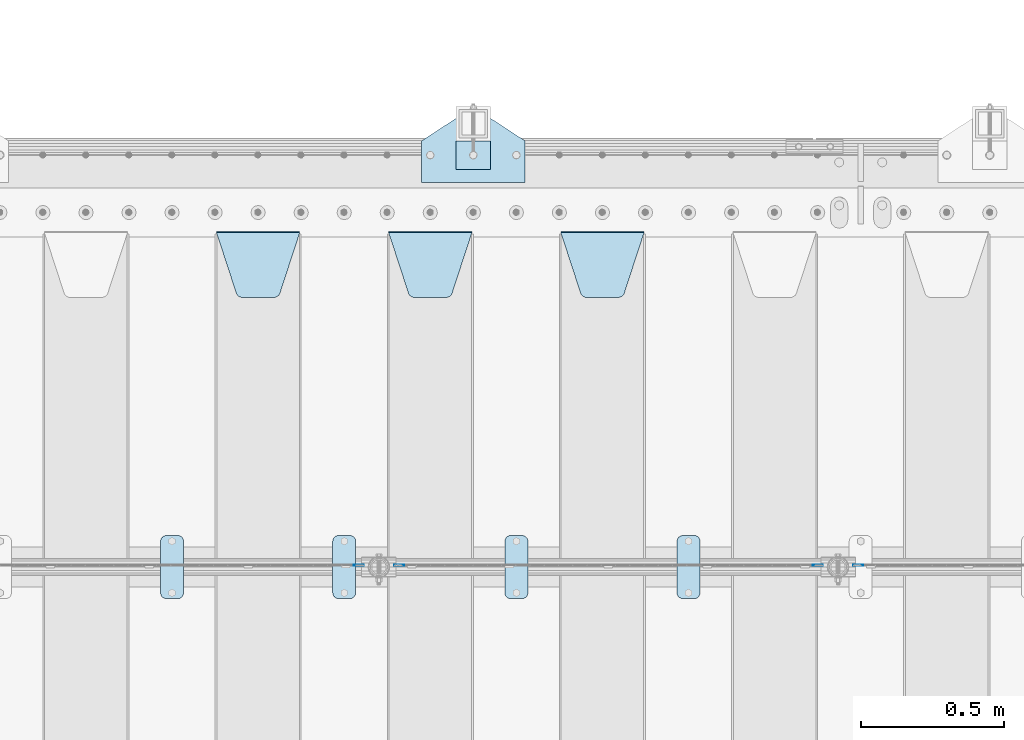
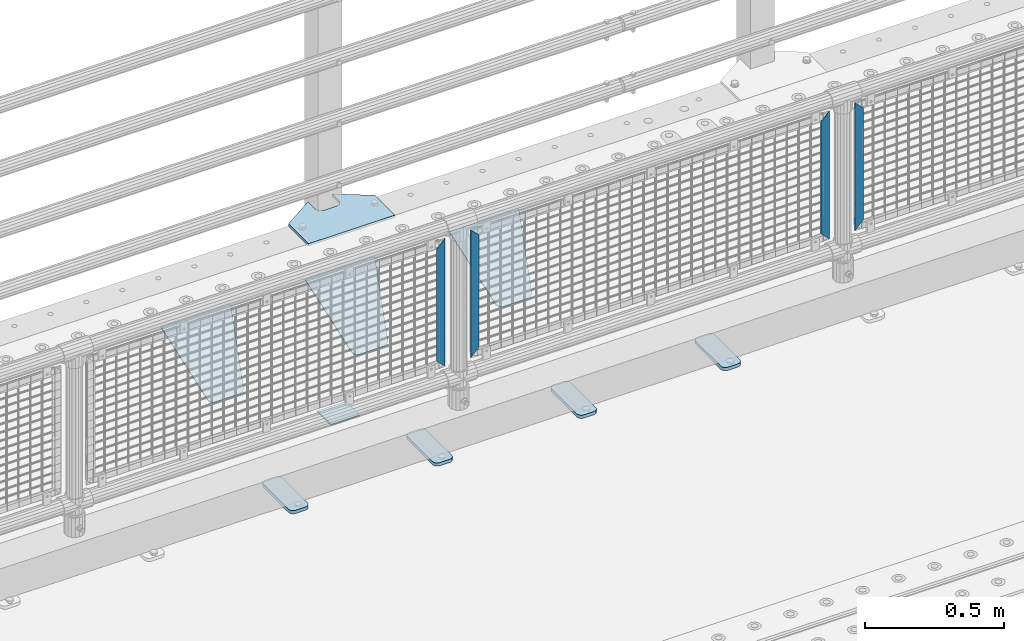
# One storey, part 215 of 247: 13 plates.
"""IFC2X3 building model written with IfcOpenShell, lengths in millimetres."""

from ifc_helpers import new_model, si_unit, frame, origin_with_axes, place, context, subcontext, project, spatial, faceted_brep, material, type_object, element, save


model = new_model("IFC2X3")

# Units and contexts
model_context = context("Model", 3, precision=1e-05, world=origin_with_axes())
body_context = subcontext(model_context, "Body", "Model", "MODEL_VIEW")
ifc_project = project(units=[si_unit("LENGTHUNIT", "METRE", prefix="MILLI"), si_unit("AREAUNIT", "SQUARE_METRE"), si_unit("VOLUMEUNIT", "CUBIC_METRE"), si_unit("MASSUNIT", "GRAM", prefix="KILO"), si_unit("TIMEUNIT", "SECOND"), si_unit("PLANEANGLEUNIT", "RADIAN"), si_unit("SOLIDANGLEUNIT", "STERADIAN"), si_unit("THERMODYNAMICTEMPERATUREUNIT", "DEGREE_CELSIUS"), si_unit("LUMINOUSINTENSITYUNIT", "LUMEN")], contexts=[model_context])

# Site, building, storey
site_placement = place(None, origin_with_axes())
site = spatial("IfcSite", under=ifc_project, at=site_placement, CompositionType="ELEMENT")
building_placement = place(site_placement, origin_with_axes())
building = spatial("IfcBuilding", under=site, at=building_placement, Name="Standard", CompositionType="ELEMENT")
storey_placement = place(building_placement, origin_with_axes())
storey = spatial("IfcBuildingStorey", under=building, at=storey_placement, Name="Undefined", CompositionType="ELEMENT", Elevation=0.0)

# Plates
ifc_material_1 = material(Name="STEEL/S355J2")
plate_type_1 = type_object("IfcPlateType", PredefinedType="NOTDEFINED")
plate_1_placement = place(storey_placement, frame((4860.0, 7774.5, 21.0199999999977), z_axis=(1.0, 0.0, 0.0), x_axis=(0.0, -0.999999999999548, -9.5100000000016e-07)))
element("IfcPlate", 1, at=plate_1_placement, inside=storey, type_object=plate_type_1, material=ifc_material_1, context=body_context, shape_type="Brep", body=[
    faceted_brep([(0.0, -7.0, 20.0), (0.0, -7.0, 60.0), (0.0, 7.0, 60.0), (0.0, 7.0, 20.0), (0.384294391935327, -7.0, 63.9018064403226), (0.384294391935327, 7.0, 63.9018064403226), (1.52240934977453, -7.0, 67.6536686473009), (1.52240934977453, 7.0, 67.6536686473009), (3.37060775394912, -7.0, 71.1114046603925), (3.37060775394912, 7.0, 71.1114046603925), (5.85786437626939, -7.0, 74.1421356237315), (5.85786437626939, 7.0, 74.1421356237315), (8.8885953396084, -7.0, 76.6293922460518), (8.8885953396084, 7.0, 76.6293922460518), (12.3463313526981, -7.0, 78.4775906502255), (12.3463313526981, 7.0, 78.4775906502255), (16.0981935596774, -7.0, 79.6157056080647), (16.0981935596774, 7.0, 79.6157056080647), (20.0, -7.0, 80.0), (20.0, 7.0, 80.0), (200.0, -7.0, 80.0), (200.0, 7.0, 80.0), (203.901806440323, -7.0, 79.6157056080647), (203.901806440323, 7.0, 79.6157056080647), (207.653668647302, -7.0, 78.4775906502255), (207.653668647302, 7.0, 78.4775906502255), (211.111404660392, -7.0, 76.6293922460518), (211.111404660392, 7.0, 76.6293922460518), (214.142135623731, -7.0, 74.1421356237315), (214.142135623731, 7.0, 74.1421356237315), (216.629392246051, -7.0, 71.1114046603925), (216.629392246051, 7.0, 71.1114046603925), (218.477590650225, -7.0, 67.6536686473009), (218.477590650225, 7.0, 67.6536686473009), (219.615705608065, -7.0, 63.9018064403226), (219.615705608065, 7.0, 63.9018064403226), (220.0, -7.0, 60.0), (220.0, 7.0, 60.0), (220.0, -7.0, 20.0), (220.0, 7.0, 20.0), (219.615705608065, -7.0, 16.0981935596774), (219.615705608065, 7.0, 16.0981935596774), (218.477590650225, -7.0, 12.3463313526991), (218.477590650225, 7.0, 12.3463313526991), (216.629392246051, -7.0, 8.88859533960749), (216.629392246051, 7.0, 8.88859533960749), (214.142135623731, -7.0, 5.85786437626848), (214.142135623731, 7.0, 5.85786437626848), (211.111404660392, -7.0, 3.37060775394821), (211.111404660392, 7.0, 3.37060775394821), (207.653668647302, -7.0, 1.52240934977453), (207.653668647302, 7.0, 1.52240934977453), (203.901806440323, -7.0, 0.384294391935327), (203.901806440323, 7.0, 0.384294391935327), (200.0, -7.0, 0.0), (200.0, 7.0, 0.0), (20.0, -7.0, 0.0), (20.0, 7.0, 0.0), (16.0981935596774, -7.0, 0.384294391935327), (16.0981935596774, 7.0, 0.384294391935327), (12.3463313526981, -7.0, 1.52240934977453), (12.3463313526981, 7.0, 1.52240934977453), (8.8885953396084, -7.0, 3.37060775394821), (8.8885953396084, 7.0, 3.37060775394821), (5.85786437626939, -7.0, 5.85786437626848), (5.85786437626939, 7.0, 5.85786437626848), (3.37060775394912, -7.0, 8.88859533960749), (3.37060775394912, 7.0, 8.88859533960749), (1.52240934977453, -7.0, 12.3463313526991), (1.52240934977453, 7.0, 12.3463313526991), (0.384294391935327, -7.0, 16.0981935596774), (0.384294391935327, 7.0, 16.0981935596774)], [[[0, 1, 2, 3]], [[1, 4, 5, 2]], [[4, 6, 7, 5]], [[6, 8, 9, 7]], [[8, 10, 11, 9]], [[10, 12, 13, 11]], [[12, 14, 15, 13]], [[14, 16, 17, 15]], [[16, 18, 19, 17]], [[18, 20, 21, 19]], [[20, 22, 23, 21]], [[22, 24, 25, 23]], [[24, 26, 27, 25]], [[26, 28, 29, 27]], [[28, 30, 31, 29]], [[30, 32, 33, 31]], [[32, 34, 35, 33]], [[34, 36, 37, 35]], [[36, 38, 39, 37]], [[38, 40, 41, 39]], [[40, 42, 43, 41]], [[42, 44, 45, 43]], [[44, 46, 47, 45]], [[46, 48, 49, 47]], [[48, 50, 51, 49]], [[50, 52, 53, 51]], [[52, 54, 55, 53]], [[54, 56, 57, 55]], [[56, 58, 59, 57]], [[58, 60, 61, 59]], [[60, 62, 63, 61]], [[62, 64, 65, 63]], [[64, 66, 67, 65]], [[66, 68, 69, 67]], [[68, 70, 71, 69]], [[70, 0, 3, 71]], [[5, 7, 9, 11, 13, 15, 17, 19, 21, 23, 25, 27, 29, 31, 33, 35, 37, 39, 41, 43, 45, 47, 49, 51, 53, 55, 57, 59, 61, 63, 65, 67, 69, 71, 3, 2]], [[70, 68, 66, 64, 62, 60, 58, 56, 54, 52, 50, 48, 46, 44, 42, 40, 38, 36, 34, 32, 30, 28, 26, 24, 22, 20, 18, 16, 14, 12, 10, 8, 6, 4, 1, 0]]]),
])
plate_2_placement = place(storey_placement, frame((4260.0, 7774.5, 21.0199999999977), z_axis=(1.0, 0.0, 0.0), x_axis=(0.0, -0.999999999999548, -9.5100000000016e-07)))
element("IfcPlate", 2, at=plate_2_placement, inside=storey, type_object=plate_type_1, material=ifc_material_1, context=body_context, shape_type="Brep", body=[
    faceted_brep([(0.0, -7.0, 20.0), (0.0, -7.0, 60.0), (0.0, 7.0, 60.0), (0.0, 7.0, 20.0), (0.384294391935327, -7.0, 63.9018064403226), (0.384294391935327, 7.0, 63.9018064403226), (1.52240934977453, -7.0, 67.6536686473009), (1.52240934977453, 7.0, 67.6536686473009), (3.37060775394912, -7.0, 71.1114046603925), (3.37060775394912, 7.0, 71.1114046603925), (5.85786437626939, -7.0, 74.1421356237315), (5.85786437626939, 7.0, 74.1421356237315), (8.8885953396084, -7.0, 76.6293922460518), (8.8885953396084, 7.0, 76.6293922460518), (12.3463313526981, -7.0, 78.4775906502255), (12.3463313526981, 7.0, 78.4775906502255), (16.0981935596774, -7.0, 79.6157056080647), (16.0981935596774, 7.0, 79.6157056080647), (20.0, -7.0, 80.0), (20.0, 7.0, 80.0), (200.0, -7.0, 80.0), (200.0, 7.0, 80.0), (203.901806440323, -7.0, 79.6157056080647), (203.901806440323, 7.0, 79.6157056080647), (207.653668647302, -7.0, 78.4775906502255), (207.653668647302, 7.0, 78.4775906502255), (211.111404660392, -7.0, 76.6293922460518), (211.111404660392, 7.0, 76.6293922460518), (214.142135623731, -7.0, 74.1421356237315), (214.142135623731, 7.0, 74.1421356237315), (216.629392246051, -7.0, 71.1114046603925), (216.629392246051, 7.0, 71.1114046603925), (218.477590650225, -7.0, 67.6536686473009), (218.477590650225, 7.0, 67.6536686473009), (219.615705608065, -7.0, 63.9018064403226), (219.615705608065, 7.0, 63.9018064403226), (220.0, -7.0, 60.0), (220.0, 7.0, 60.0), (220.0, -7.0, 20.0), (220.0, 7.0, 20.0), (219.615705608065, -7.0, 16.0981935596774), (219.615705608065, 7.0, 16.0981935596774), (218.477590650225, -7.0, 12.3463313526991), (218.477590650225, 7.0, 12.3463313526991), (216.629392246051, -7.0, 8.88859533960749), (216.629392246051, 7.0, 8.88859533960749), (214.142135623731, -7.0, 5.85786437626848), (214.142135623731, 7.0, 5.85786437626848), (211.111404660392, -7.0, 3.37060775394821), (211.111404660392, 7.0, 3.37060775394821), (207.653668647302, -7.0, 1.52240934977453), (207.653668647302, 7.0, 1.52240934977453), (203.901806440323, -7.0, 0.384294391935327), (203.901806440323, 7.0, 0.384294391935327), (200.0, -7.0, 0.0), (200.0, 7.0, 0.0), (20.0, -7.0, 0.0), (20.0, 7.0, 0.0), (16.0981935596774, -7.0, 0.384294391935327), (16.0981935596774, 7.0, 0.384294391935327), (12.3463313526981, -7.0, 1.52240934977453), (12.3463313526981, 7.0, 1.52240934977453), (8.8885953396084, -7.0, 3.37060775394821), (8.8885953396084, 7.0, 3.37060775394821), (5.85786437626939, -7.0, 5.85786437626848), (5.85786437626939, 7.0, 5.85786437626848), (3.37060775394912, -7.0, 8.88859533960749), (3.37060775394912, 7.0, 8.88859533960749), (1.52240934977453, -7.0, 12.3463313526991), (1.52240934977453, 7.0, 12.3463313526991), (0.384294391935327, -7.0, 16.0981935596774), (0.384294391935327, 7.0, 16.0981935596774)], [[[0, 1, 2, 3]], [[1, 4, 5, 2]], [[4, 6, 7, 5]], [[6, 8, 9, 7]], [[8, 10, 11, 9]], [[10, 12, 13, 11]], [[12, 14, 15, 13]], [[14, 16, 17, 15]], [[16, 18, 19, 17]], [[18, 20, 21, 19]], [[20, 22, 23, 21]], [[22, 24, 25, 23]], [[24, 26, 27, 25]], [[26, 28, 29, 27]], [[28, 30, 31, 29]], [[30, 32, 33, 31]], [[32, 34, 35, 33]], [[34, 36, 37, 35]], [[36, 38, 39, 37]], [[38, 40, 41, 39]], [[40, 42, 43, 41]], [[42, 44, 45, 43]], [[44, 46, 47, 45]], [[46, 48, 49, 47]], [[48, 50, 51, 49]], [[50, 52, 53, 51]], [[52, 54, 55, 53]], [[54, 56, 57, 55]], [[56, 58, 59, 57]], [[58, 60, 61, 59]], [[60, 62, 63, 61]], [[62, 64, 65, 63]], [[64, 66, 67, 65]], [[66, 68, 69, 67]], [[68, 70, 71, 69]], [[70, 0, 3, 71]], [[5, 7, 9, 11, 13, 15, 17, 19, 21, 23, 25, 27, 29, 31, 33, 35, 37, 39, 41, 43, 45, 47, 49, 51, 53, 55, 57, 59, 61, 63, 65, 67, 69, 71, 3, 2]], [[70, 68, 66, 64, 62, 60, 58, 56, 54, 52, 50, 48, 46, 44, 42, 40, 38, 36, 34, 32, 30, 28, 26, 24, 22, 20, 18, 16, 14, 12, 10, 8, 6, 4, 1, 0]]]),
])
plate_3_placement = place(storey_placement, frame((3660.0, 7774.5, 21.0199999999977), z_axis=(1.0, 0.0, 0.0), x_axis=(0.0, -0.999999999999548, -9.5100000000016e-07)))
element("IfcPlate", 3, at=plate_3_placement, inside=storey, type_object=plate_type_1, material=ifc_material_1, context=body_context, shape_type="Brep", body=[
    faceted_brep([(0.0, -7.0, 20.0), (0.0, -7.0, 60.0), (0.0, 7.0, 60.0), (0.0, 7.0, 20.0), (0.384294391935327, -7.0, 63.9018064403226), (0.384294391935327, 7.0, 63.9018064403226), (1.52240934977453, -7.0, 67.6536686473009), (1.52240934977453, 7.0, 67.6536686473009), (3.37060775394912, -7.0, 71.1114046603925), (3.37060775394912, 7.0, 71.1114046603925), (5.85786437626939, -7.0, 74.1421356237315), (5.85786437626939, 7.0, 74.1421356237315), (8.8885953396084, -7.0, 76.6293922460518), (8.8885953396084, 7.0, 76.6293922460518), (12.3463313526981, -7.0, 78.4775906502255), (12.3463313526981, 7.0, 78.4775906502255), (16.0981935596774, -7.0, 79.6157056080647), (16.0981935596774, 7.0, 79.6157056080647), (20.0, -7.0, 80.0), (20.0, 7.0, 80.0), (200.0, -7.0, 80.0), (200.0, 7.0, 80.0), (203.901806440323, -7.0, 79.6157056080647), (203.901806440323, 7.0, 79.6157056080647), (207.653668647302, -7.0, 78.4775906502255), (207.653668647302, 7.0, 78.4775906502255), (211.111404660392, -7.0, 76.6293922460518), (211.111404660392, 7.0, 76.6293922460518), (214.142135623731, -7.0, 74.1421356237315), (214.142135623731, 7.0, 74.1421356237315), (216.629392246051, -7.0, 71.1114046603925), (216.629392246051, 7.0, 71.1114046603925), (218.477590650225, -7.0, 67.6536686473009), (218.477590650225, 7.0, 67.6536686473009), (219.615705608065, -7.0, 63.9018064403226), (219.615705608065, 7.0, 63.9018064403226), (220.0, -7.0, 60.0), (220.0, 7.0, 60.0), (220.0, -7.0, 20.0), (220.0, 7.0, 20.0), (219.615705608065, -7.0, 16.0981935596774), (219.615705608065, 7.0, 16.0981935596774), (218.477590650225, -7.0, 12.3463313526991), (218.477590650225, 7.0, 12.3463313526991), (216.629392246051, -7.0, 8.88859533960749), (216.629392246051, 7.0, 8.88859533960749), (214.142135623731, -7.0, 5.85786437626848), (214.142135623731, 7.0, 5.85786437626848), (211.111404660392, -7.0, 3.37060775394821), (211.111404660392, 7.0, 3.37060775394821), (207.653668647302, -7.0, 1.52240934977453), (207.653668647302, 7.0, 1.52240934977453), (203.901806440323, -7.0, 0.384294391935327), (203.901806440323, 7.0, 0.384294391935327), (200.0, -7.0, 0.0), (200.0, 7.0, 0.0), (20.0, -7.0, 0.0), (20.0, 7.0, 0.0), (16.0981935596774, -7.0, 0.384294391935327), (16.0981935596774, 7.0, 0.384294391935327), (12.3463313526981, -7.0, 1.52240934977453), (12.3463313526981, 7.0, 1.52240934977453), (8.8885953396084, -7.0, 3.37060775394821), (8.8885953396084, 7.0, 3.37060775394821), (5.85786437626939, -7.0, 5.85786437626848), (5.85786437626939, 7.0, 5.85786437626848), (3.37060775394912, -7.0, 8.88859533960749), (3.37060775394912, 7.0, 8.88859533960749), (1.52240934977453, -7.0, 12.3463313526991), (1.52240934977453, 7.0, 12.3463313526991), (0.384294391935327, -7.0, 16.0981935596774), (0.384294391935327, 7.0, 16.0981935596774)], [[[0, 1, 2, 3]], [[1, 4, 5, 2]], [[4, 6, 7, 5]], [[6, 8, 9, 7]], [[8, 10, 11, 9]], [[10, 12, 13, 11]], [[12, 14, 15, 13]], [[14, 16, 17, 15]], [[16, 18, 19, 17]], [[18, 20, 21, 19]], [[20, 22, 23, 21]], [[22, 24, 25, 23]], [[24, 26, 27, 25]], [[26, 28, 29, 27]], [[28, 30, 31, 29]], [[30, 32, 33, 31]], [[32, 34, 35, 33]], [[34, 36, 37, 35]], [[36, 38, 39, 37]], [[38, 40, 41, 39]], [[40, 42, 43, 41]], [[42, 44, 45, 43]], [[44, 46, 47, 45]], [[46, 48, 49, 47]], [[48, 50, 51, 49]], [[50, 52, 53, 51]], [[52, 54, 55, 53]], [[54, 56, 57, 55]], [[56, 58, 59, 57]], [[58, 60, 61, 59]], [[60, 62, 63, 61]], [[62, 64, 65, 63]], [[64, 66, 67, 65]], [[66, 68, 69, 67]], [[68, 70, 71, 69]], [[70, 0, 3, 71]], [[5, 7, 9, 11, 13, 15, 17, 19, 21, 23, 25, 27, 29, 31, 33, 35, 37, 39, 41, 43, 45, 47, 49, 51, 53, 55, 57, 59, 61, 63, 65, 67, 69, 71, 3, 2]], [[70, 68, 66, 64, 62, 60, 58, 56, 54, 52, 50, 48, 46, 44, 42, 40, 38, 36, 34, 32, 30, 28, 26, 24, 22, 20, 18, 16, 14, 12, 10, 8, 6, 4, 1, 0]]]),
])
plate_4_placement = place(storey_placement, frame((3060.0, 7774.5, 21.0199999999977), z_axis=(1.0, 0.0, 0.0), x_axis=(0.0, -0.999999999999548, -9.5100000000016e-07)))
element("IfcPlate", 4, at=plate_4_placement, inside=storey, type_object=plate_type_1, material=ifc_material_1, context=body_context, shape_type="Brep", body=[
    faceted_brep([(0.0, -7.0, 20.0), (0.0, -7.0, 60.0), (0.0, 7.0, 60.0), (0.0, 7.0, 20.0), (0.384294391935327, -7.0, 63.9018064403226), (0.384294391935327, 7.0, 63.9018064403226), (1.52240934977453, -7.0, 67.6536686473009), (1.52240934977453, 7.0, 67.6536686473009), (3.37060775394912, -7.0, 71.1114046603925), (3.37060775394912, 7.0, 71.1114046603925), (5.85786437626939, -7.0, 74.1421356237315), (5.85786437626939, 7.0, 74.1421356237315), (8.8885953396084, -7.0, 76.6293922460518), (8.8885953396084, 7.0, 76.6293922460518), (12.3463313526981, -7.0, 78.4775906502255), (12.3463313526981, 7.0, 78.4775906502255), (16.0981935596774, -7.0, 79.6157056080647), (16.0981935596774, 7.0, 79.6157056080647), (20.0, -7.0, 80.0), (20.0, 7.0, 80.0), (200.0, -7.0, 80.0), (200.0, 7.0, 80.0), (203.901806440323, -7.0, 79.6157056080647), (203.901806440323, 7.0, 79.6157056080647), (207.653668647302, -7.0, 78.4775906502255), (207.653668647302, 7.0, 78.4775906502255), (211.111404660392, -7.0, 76.6293922460518), (211.111404660392, 7.0, 76.6293922460518), (214.142135623731, -7.0, 74.1421356237315), (214.142135623731, 7.0, 74.1421356237315), (216.629392246051, -7.0, 71.1114046603925), (216.629392246051, 7.0, 71.1114046603925), (218.477590650225, -7.0, 67.6536686473009), (218.477590650225, 7.0, 67.6536686473009), (219.615705608065, -7.0, 63.9018064403226), (219.615705608065, 7.0, 63.9018064403226), (220.0, -7.0, 60.0), (220.0, 7.0, 60.0), (220.0, -7.0, 20.0), (220.0, 7.0, 20.0), (219.615705608065, -7.0, 16.0981935596774), (219.615705608065, 7.0, 16.0981935596774), (218.477590650225, -7.0, 12.3463313526991), (218.477590650225, 7.0, 12.3463313526991), (216.629392246051, -7.0, 8.88859533960749), (216.629392246051, 7.0, 8.88859533960749), (214.142135623731, -7.0, 5.85786437626848), (214.142135623731, 7.0, 5.85786437626848), (211.111404660392, -7.0, 3.37060775394821), (211.111404660392, 7.0, 3.37060775394821), (207.653668647302, -7.0, 1.52240934977453), (207.653668647302, 7.0, 1.52240934977453), (203.901806440323, -7.0, 0.384294391935327), (203.901806440323, 7.0, 0.384294391935327), (200.0, -7.0, 0.0), (200.0, 7.0, 0.0), (20.0, -7.0, 0.0), (20.0, 7.0, 0.0), (16.0981935596774, -7.0, 0.384294391935327), (16.0981935596774, 7.0, 0.384294391935327), (12.3463313526981, -7.0, 1.52240934977453), (12.3463313526981, 7.0, 1.52240934977453), (8.8885953396084, -7.0, 3.37060775394821), (8.8885953396084, 7.0, 3.37060775394821), (5.85786437626939, -7.0, 5.85786437626848), (5.85786437626939, 7.0, 5.85786437626848), (3.37060775394912, -7.0, 8.88859533960749), (3.37060775394912, 7.0, 8.88859533960749), (1.52240934977453, -7.0, 12.3463313526991), (1.52240934977453, 7.0, 12.3463313526991), (0.384294391935327, -7.0, 16.0981935596774), (0.384294391935327, 7.0, 16.0981935596774)], [[[0, 1, 2, 3]], [[1, 4, 5, 2]], [[4, 6, 7, 5]], [[6, 8, 9, 7]], [[8, 10, 11, 9]], [[10, 12, 13, 11]], [[12, 14, 15, 13]], [[14, 16, 17, 15]], [[16, 18, 19, 17]], [[18, 20, 21, 19]], [[20, 22, 23, 21]], [[22, 24, 25, 23]], [[24, 26, 27, 25]], [[26, 28, 29, 27]], [[28, 30, 31, 29]], [[30, 32, 33, 31]], [[32, 34, 35, 33]], [[34, 36, 37, 35]], [[36, 38, 39, 37]], [[38, 40, 41, 39]], [[40, 42, 43, 41]], [[42, 44, 45, 43]], [[44, 46, 47, 45]], [[46, 48, 49, 47]], [[48, 50, 51, 49]], [[50, 52, 53, 51]], [[52, 54, 55, 53]], [[54, 56, 57, 55]], [[56, 58, 59, 57]], [[58, 60, 61, 59]], [[60, 62, 63, 61]], [[62, 64, 65, 63]], [[64, 66, 67, 65]], [[66, 68, 69, 67]], [[68, 70, 71, 69]], [[70, 0, 3, 71]], [[5, 7, 9, 11, 13, 15, 17, 19, 21, 23, 25, 27, 29, 31, 33, 35, 37, 39, 41, 43, 45, 47, 49, 51, 53, 55, 57, 59, 61, 63, 65, 67, 69, 71, 3, 2]], [[70, 68, 66, 64, 62, 60, 58, 56, 54, 52, 50, 48, 46, 44, 42, 40, 38, 36, 34, 32, 30, 28, 26, 24, 22, 20, 18, 16, 14, 12, 10, 8, 6, 4, 1, 0]]]),
])
ifc_material_2 = material(Name="STEEL/S355N")
plate_type_2 = type_object("IfcPlateType", PredefinedType="NOTDEFINED")
plate_5_placement = place(storey_placement, frame((4455.0, 8831.76776695594, -1.767766952965), z_axis=(0.0, -0.707106781186548, -0.707106781186547), x_axis=(1.0, 0.0, 0.0)))
element("IfcPlate", 5, at=plate_5_placement, inside=storey, type_object=plate_type_2, material=ifc_material_2, context=body_context, shape_type="Brep", body=[
    faceted_brep([(0.0, -2.49999999999909, 0.0), (69.345504679477, -2.5, 300.17173142483), (69.345504679477, 2.50000000000091, 300.171731424831), (0.0, 2.5, -9.09494701772928e-13), (70.9274061199576, -2.5, 304.897442415399), (70.9274061199576, 2.50000000000091, 304.8974424154), (73.3818627772307, -2.49999999999909, 309.234538108527), (73.3818627772307, 2.5, 309.234538108526), (76.6187032999551, -2.5, 313.023683126102), (76.6187032999551, 2.50000000000091, 313.023683126102), (80.5190132704993, -2.49999999999909, 316.125672595371), (80.5190132704993, 2.50000000000091, 316.125672595372), (84.9395038596849, -2.49999999999909, 318.426546230476), (84.9395038596849, 2.5, 318.426546230475), (89.7177759439219, -2.5, 319.841774983274), (89.7177759439219, 2.50000000000091, 319.841774983275), (94.678286292652, -2.5, 320.319366455077), (94.678286292652, 2.50000000000091, 320.319366455077), (195.321713707348, -2.5, 320.319366455077), (195.321713707348, 2.50000000000091, 320.319366455077), (200.282224056078, -2.5, 319.841774983274), (200.282224056078, 2.50000000000091, 319.841774983275), (205.060496140315, -2.5, 318.426546230475), (205.060496140315, 2.5, 318.426546230474), (209.480986729501, -2.49999999999818, 316.12567259537), (209.480986729501, 2.50000000000091, 316.12567259537), (213.381296700045, -2.5, 313.023683126101), (213.381296700045, 2.50000000000091, 313.023683126101), (216.618137222769, -2.5, 309.234538108525), (216.618137222769, 2.5, 309.234538108525), (219.072593880042, -2.49999999999909, 304.897442415398), (219.072593880042, 2.5, 304.897442415398), (220.654495320523, -2.5, 300.17173142483), (220.654495320523, 2.50000000000091, 300.171731424831), (290.0, -2.49999999999909, 0.0), (290.0, 2.5, -9.09494701772928e-13)], [[[0, 1, 2, 3]], [[1, 4, 5, 2]], [[4, 6, 7, 5]], [[6, 8, 9, 7]], [[8, 10, 11, 9]], [[10, 12, 13, 11]], [[12, 14, 15, 13]], [[14, 16, 17, 15]], [[16, 18, 19, 17]], [[18, 20, 21, 19]], [[20, 22, 23, 21]], [[22, 24, 25, 23]], [[24, 26, 27, 25]], [[26, 28, 29, 27]], [[28, 30, 31, 29]], [[30, 32, 33, 31]], [[32, 34, 35, 33]], [[34, 0, 3, 35]], [[5, 7, 9, 11, 13, 15, 17, 19, 21, 23, 25, 27, 29, 31, 33, 35, 3, 2]], [[34, 32, 30, 28, 26, 24, 22, 20, 18, 16, 14, 12, 10, 8, 6, 4, 1, 0]]]),
])
plate_6_placement = place(storey_placement, frame((3855.0, 8831.76776695594, -1.767766952965), z_axis=(0.0, -0.707106781186548, -0.707106781186547), x_axis=(1.0, 0.0, 0.0)))
element("IfcPlate", 6, at=plate_6_placement, inside=storey, type_object=plate_type_2, material=ifc_material_2, context=body_context, shape_type="Brep", body=[
    faceted_brep([(0.0, -2.49999999999909, 0.0), (69.345504679477, -2.5, 300.17173142483), (69.345504679477, 2.50000000000091, 300.171731424831), (0.0, 2.5, -9.09494701772928e-13), (70.9274061199576, -2.5, 304.897442415399), (70.9274061199576, 2.50000000000091, 304.8974424154), (73.3818627772307, -2.49999999999909, 309.234538108527), (73.3818627772307, 2.5, 309.234538108526), (76.6187032999551, -2.5, 313.023683126102), (76.6187032999551, 2.50000000000091, 313.023683126102), (80.5190132704993, -2.49999999999909, 316.125672595371), (80.5190132704993, 2.50000000000091, 316.125672595372), (84.9395038596849, -2.49999999999909, 318.426546230476), (84.9395038596849, 2.5, 318.426546230475), (89.7177759439219, -2.5, 319.841774983274), (89.7177759439219, 2.50000000000091, 319.841774983275), (94.678286292652, -2.5, 320.319366455077), (94.678286292652, 2.50000000000091, 320.319366455077), (195.321713707348, -2.5, 320.319366455077), (195.321713707348, 2.50000000000091, 320.319366455077), (200.282224056078, -2.5, 319.841774983274), (200.282224056078, 2.50000000000091, 319.841774983275), (205.060496140315, -2.5, 318.426546230475), (205.060496140315, 2.5, 318.426546230474), (209.480986729501, -2.49999999999818, 316.12567259537), (209.480986729501, 2.50000000000091, 316.12567259537), (213.381296700045, -2.5, 313.023683126101), (213.381296700045, 2.50000000000091, 313.023683126101), (216.618137222769, -2.5, 309.234538108525), (216.618137222769, 2.5, 309.234538108525), (219.072593880042, -2.49999999999909, 304.897442415398), (219.072593880042, 2.5, 304.897442415398), (220.654495320523, -2.5, 300.17173142483), (220.654495320523, 2.50000000000091, 300.171731424831), (290.0, -2.49999999999909, 0.0), (290.0, 2.5, -9.09494701772928e-13)], [[[0, 1, 2, 3]], [[1, 4, 5, 2]], [[4, 6, 7, 5]], [[6, 8, 9, 7]], [[8, 10, 11, 9]], [[10, 12, 13, 11]], [[12, 14, 15, 13]], [[14, 16, 17, 15]], [[16, 18, 19, 17]], [[18, 20, 21, 19]], [[20, 22, 23, 21]], [[22, 24, 25, 23]], [[24, 26, 27, 25]], [[26, 28, 29, 27]], [[28, 30, 31, 29]], [[30, 32, 33, 31]], [[32, 34, 35, 33]], [[34, 0, 3, 35]], [[5, 7, 9, 11, 13, 15, 17, 19, 21, 23, 25, 27, 29, 31, 33, 35, 3, 2]], [[34, 32, 30, 28, 26, 24, 22, 20, 18, 16, 14, 12, 10, 8, 6, 4, 1, 0]]]),
])
plate_7_placement = place(storey_placement, frame((3255.0, 8831.76776695594, -1.767766952965), z_axis=(0.0, -0.707106781186548, -0.707106781186547), x_axis=(1.0, 0.0, 0.0)))
element("IfcPlate", 7, at=plate_7_placement, inside=storey, type_object=plate_type_2, material=ifc_material_2, context=body_context, shape_type="Brep", body=[
    faceted_brep([(0.0, -2.49999999999909, 0.0), (69.345504679477, -2.5, 300.17173142483), (69.345504679477, 2.50000000000091, 300.171731424831), (0.0, 2.5, -9.09494701772928e-13), (70.9274061199576, -2.5, 304.897442415399), (70.9274061199576, 2.50000000000091, 304.8974424154), (73.3818627772307, -2.49999999999909, 309.234538108527), (73.3818627772307, 2.5, 309.234538108526), (76.6187032999551, -2.5, 313.023683126102), (76.6187032999551, 2.50000000000091, 313.023683126102), (80.5190132704993, -2.49999999999909, 316.125672595371), (80.5190132704993, 2.50000000000091, 316.125672595372), (84.9395038596849, -2.49999999999909, 318.426546230476), (84.9395038596849, 2.5, 318.426546230475), (89.7177759439219, -2.5, 319.841774983274), (89.7177759439219, 2.50000000000091, 319.841774983275), (94.678286292652, -2.5, 320.319366455077), (94.678286292652, 2.50000000000091, 320.319366455077), (195.321713707348, -2.5, 320.319366455077), (195.321713707348, 2.50000000000091, 320.319366455077), (200.282224056078, -2.5, 319.841774983274), (200.282224056078, 2.50000000000091, 319.841774983275), (205.060496140315, -2.5, 318.426546230475), (205.060496140315, 2.5, 318.426546230474), (209.480986729501, -2.49999999999818, 316.12567259537), (209.480986729501, 2.50000000000091, 316.12567259537), (213.381296700045, -2.5, 313.023683126101), (213.381296700045, 2.50000000000091, 313.023683126101), (216.618137222769, -2.5, 309.234538108525), (216.618137222769, 2.5, 309.234538108525), (219.072593880042, -2.49999999999909, 304.897442415398), (219.072593880042, 2.5, 304.897442415398), (220.654495320523, -2.5, 300.17173142483), (220.654495320523, 2.50000000000091, 300.171731424831), (290.0, -2.49999999999909, 0.0), (290.0, 2.5, -9.09494701772928e-13)], [[[0, 1, 2, 3]], [[1, 4, 5, 2]], [[4, 6, 7, 5]], [[6, 8, 9, 7]], [[8, 10, 11, 9]], [[10, 12, 13, 11]], [[12, 14, 15, 13]], [[14, 16, 17, 15]], [[16, 18, 19, 17]], [[18, 20, 21, 19]], [[20, 22, 23, 21]], [[22, 24, 25, 23]], [[24, 26, 27, 25]], [[26, 28, 29, 27]], [[28, 30, 31, 29]], [[30, 32, 33, 31]], [[32, 34, 35, 33]], [[34, 0, 3, 35]], [[5, 7, 9, 11, 13, 15, 17, 19, 21, 23, 25, 27, 29, 31, 33, 35, 3, 2]], [[34, 32, 30, 28, 26, 24, 22, 20, 18, 16, 14, 12, 10, 8, 6, 4, 1, 0]]]),
])
ifc_material_3 = material(Name="Misc_Undefined")
plate_type_3 = type_object("IfcPlateType", PredefinedType="NOTDEFINED")
for number, where, z_axis, x_axis in (
    (8, (5509.50971354097, 7670.5, 879.519963133601), (-0.707008801899319, 0.0, -0.707204746899291), (-0.707204746899294, 0.0, 0.707008801899315)),
    (9, (3909.50971354097, 7670.5, 879.519963133601), (-0.707008801899319, 0.0, -0.707204746899291), (-0.707204746899294, 0.0, 0.707008801899315)),
):
    element("IfcPlate", number, at=place(storey_placement, frame(where, z_axis=z_axis, x_axis=x_axis)), inside=storey, type_object=plate_type_3, material=ifc_material_3, context=body_context, shape_type="Brep", body=[
        faceted_brep([(1.81898940354586e-12, -1.5, -5.6843418860808e-14), (-348.552185058596, -1.5, 348.655029296875), (-348.552185058596, 1.5, 348.655029296875), (1.81898940354586e-12, 1.5, -5.6843418860808e-14), (-348.544891357424, -1.5, 398.152496337891), (-348.544891357424, 1.5, 398.152496337891), (49.50439453125, -1.5, 7.6397554948926e-11), (49.50439453125, 1.5, 7.6397554948926e-11)], [[[0, 1, 2, 3]], [[1, 4, 5, 2]], [[4, 6, 7, 5]], [[6, 0, 3, 7]], [[5, 7, 3, 2]], [[6, 4, 1, 0]]]),
    ])
for number, where, z_axis, x_axis in (
    (10, (5332.49968748361, 7670.5, 879.52), (0.707103624179499, 0.0, -0.707109938179501), (0.707109938179497, 0.0, 0.707103624179503)),
    (11, (3732.49968748361, 7670.5, 879.52), (0.707103624179499, 0.0, -0.707109938179501), (0.707109938179497, 0.0, 0.707103624179503)),
):
    element("IfcPlate", number, at=place(storey_placement, frame(where, z_axis=z_axis, x_axis=x_axis)), inside=storey, type_object=plate_type_3, material=ifc_material_3, context=body_context, shape_type="Brep", body=[
        faceted_brep([(1.81898940354586e-12, -1.5, -5.6843418860808e-14), (-348.605163574215, -1.5, 348.60208129883), (-348.605163574215, 1.5, 348.60208129883), (1.81898940354586e-12, 1.5, -5.6843418860808e-14), (-348.605163574215, -1.5, 398.099334716799), (-348.605163574215, 1.5, 398.099334716799), (49.4976959228497, -1.5, 7.09405867382884e-11), (49.4976959228497, 1.5, 7.09405867382884e-11)], [[[0, 1, 2, 3]], [[1, 4, 5, 2]], [[4, 6, 7, 5]], [[6, 0, 3, 7]], [[5, 7, 3, 2]], [[6, 4, 1, 0]]]),
    ])
plate_type_4 = type_object("IfcPlateType", PredefinedType="NOTDEFINED")
plate_8_placement = place(storey_placement, frame((3970.0, 9005.0, 5.00000000004911), z_axis=(0.0, 1.0, 0.0), x_axis=(1.0, 0.0, 0.0)))
element("IfcPlate", 12, at=plate_8_placement, inside=storey, type_object=plate_type_4, material=ifc_material_1, context=body_context, shape_type="Brep", body=[
    faceted_brep([(9.04219632502645e-09, -5.00000000143385, -2.89173840428703e-09), (2.31396552408114e-06, -5.0, 145.0), (2.31396552408114e-06, 5.0, 145.0), (7.66340235713869e-09, 4.99999999856618, -2.89173840428703e-09), (130.0, -5.0, 230.0), (130.0, 5.0, 230.0), (130.0, -5.0, 180.0), (130.0, 5.0, 180.0), (130.48036798992, -5.0, 175.122741949597), (130.48036798992, 5.0, 175.122741949597), (131.903011687218, -5.0, 170.432914190873), (131.903011687218, 5.0, 170.432914190873), (134.213259692437, -5.0, 166.11074417451), (134.213259692437, 5.0, 166.11074417451), (137.322330470337, -5.0, 162.322330470337), (137.322330470337, 5.0, 162.322330470337), (141.11074417451, -5.0, 159.213259692437), (141.11074417451, 5.0, 159.213259692437), (145.432914190873, -5.0, 156.903011687218), (145.432914190873, 5.0, 156.903011687218), (150.122741949597, -5.0, 155.48036798992), (150.122741949597, 5.0, 155.48036798992), (155.0, -5.0, 155.0), (155.0, 5.0, 155.0), (205.0, -5.0, 155.0), (205.0, 5.0, 155.0), (209.877258050403, -5.0, 155.48036798992), (209.877258050403, 5.0, 155.48036798992), (214.567085809127, -5.0, 156.903011687218), (214.567085809127, 5.0, 156.903011687218), (218.88925582549, -5.0, 159.213259692437), (218.88925582549, 5.0, 159.213259692437), (222.677669529663, -5.0, 162.322330470337), (222.677669529663, 5.0, 162.322330470337), (225.786740307563, -5.0, 166.11074417451), (225.786740307563, 5.0, 166.11074417451), (228.096988312782, -5.0, 170.432914190873), (228.096988312782, 5.0, 170.432914190873), (229.51963201008, -5.0, 175.122741949597), (229.51963201008, 5.0, 175.122741949597), (230.0, -5.0, 180.0), (230.0, 5.0, 180.0), (230.0, -5.0, 230.0), (230.0, 5.0, 230.0), (360.0, -5.0, 145.0), (360.0, 5.0, 145.0), (360.0, -5.0, -7.27595761418343e-12), (360.0, 5.0, -7.27595761418343e-12)], [[[0, 1, 2, 3]], [[1, 4, 5, 2]], [[4, 6, 7, 5]], [[6, 8, 9, 7]], [[8, 10, 11, 9]], [[10, 12, 13, 11]], [[12, 14, 15, 13]], [[14, 16, 17, 15]], [[16, 18, 19, 17]], [[18, 20, 21, 19]], [[20, 22, 23, 21]], [[22, 24, 25, 23]], [[24, 26, 27, 25]], [[26, 28, 29, 27]], [[28, 30, 31, 29]], [[30, 32, 33, 31]], [[32, 34, 35, 33]], [[34, 36, 37, 35]], [[36, 38, 39, 37]], [[38, 40, 41, 39]], [[40, 42, 43, 41]], [[42, 44, 45, 43]], [[44, 46, 47, 45]], [[46, 0, 3, 47]], [[5, 7, 9, 11, 13, 15, 17, 19, 21, 23, 25, 27, 29, 31, 33, 35, 37, 39, 41, 43, 45, 47, 3, 2]], [[46, 44, 42, 40, 38, 36, 34, 32, 30, 28, 26, 24, 22, 20, 18, 16, 14, 12, 10, 8, 6, 4, 1, 0]]]),
])
plate_type_5 = type_object("IfcPlateType", PredefinedType="NOTDEFINED")
plate_9_placement = place(storey_placement, frame((4090.00000000014, 9050.00000000021, -857.500000000002), z_axis=(0.0, 1.0, 0.0), x_axis=(1.0, 0.0, 0.0)))
element("IfcPlate", 13, at=plate_9_placement, inside=storey, type_object=plate_type_5, material=ifc_material_1, context=body_context, shape_type="Brep", body=[
    faceted_brep([(0.0, -2.49999999999909, 0.0), (0.0, -2.5, 100.0), (0.0, 2.5, 100.0), (0.0, 2.5, -9.09494701772928e-13), (120.0, -2.5, 100.0), (120.0, 2.5, 100.0), (120.0, -2.5, 0.0), (120.0, 2.5, 0.0)], [[[0, 1, 2, 3]], [[1, 4, 5, 2]], [[4, 6, 7, 5]], [[6, 0, 3, 7]], [[5, 7, 3, 2]], [[6, 4, 1, 0]]]),
])

save(model, "model.ifc")
